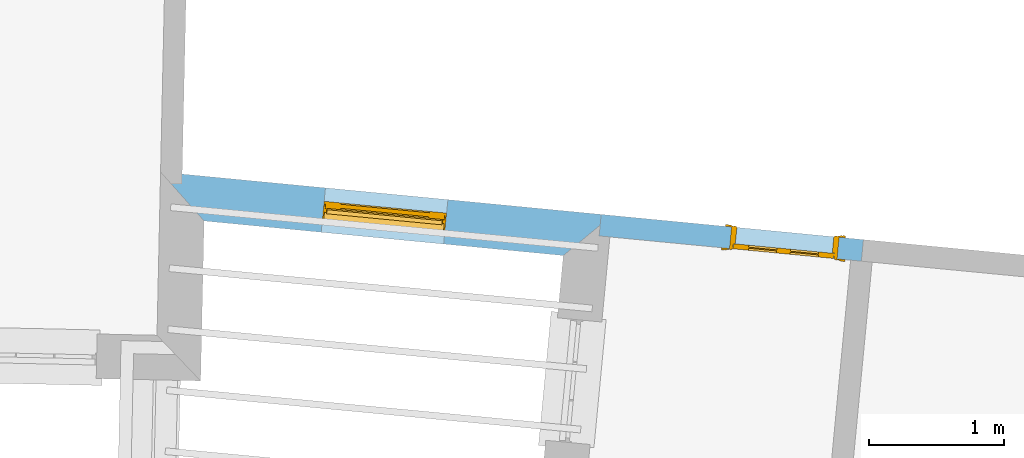
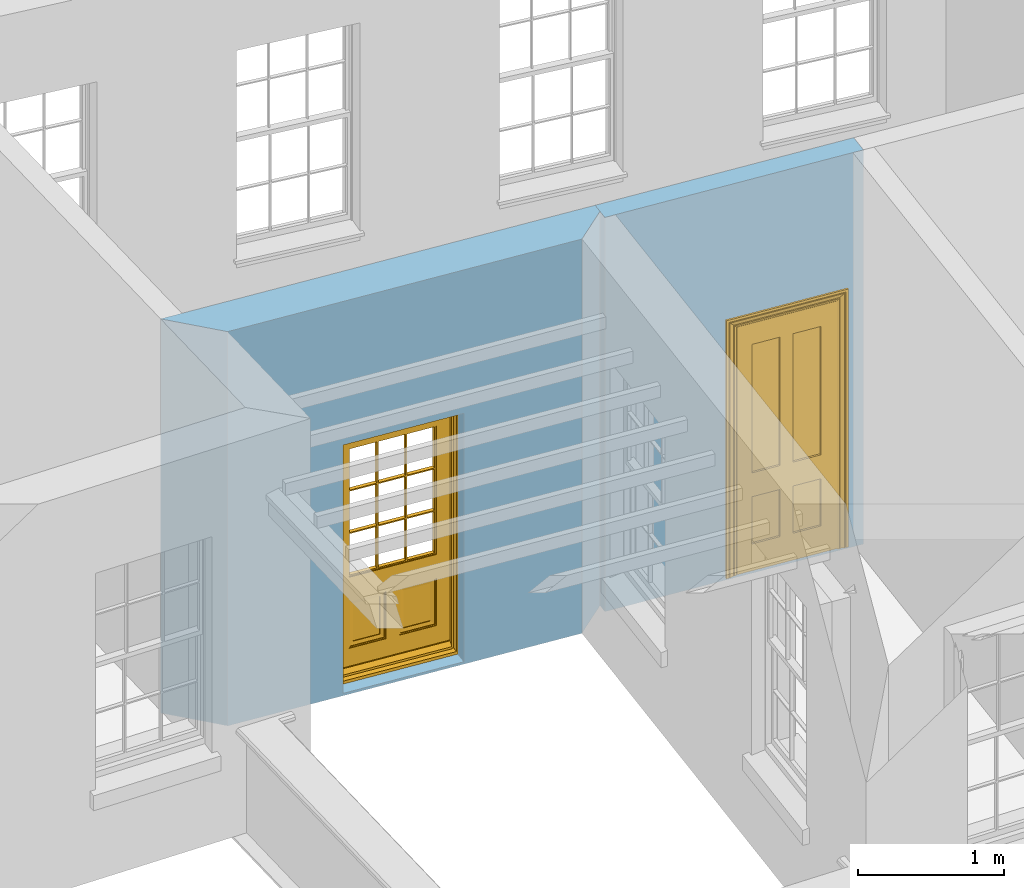
# One storey, part 6 of 12: 2 doors, 2 openings, plus 2 elements that do not belong to this part.
"""IFC2X3 building model written with IfcOpenShell, lengths in metres."""

from ifc_helpers import new_model, si_unit, frame, origin, place, context, subcontext, project, spatial, polyline, outline, extrude, faceted_brep, material, layer, layer_set, layer_usage, element, fill, save


model = new_model("IFC2X3")

# Units and contexts
model_context = context("Model", 3, world=origin())
body_context = subcontext(model_context, "Body", "Model", "MODEL_VIEW")
ifc_project = project(units=[si_unit("PLANEANGLEUNIT", "RADIAN"), si_unit("MASSUNIT", "GRAM", prefix="KILO"), si_unit("FORCEUNIT", "NEWTON", prefix="KILO"), si_unit("LENGTHUNIT", "METRE")], contexts=[model_context])

# Site, building, storey
site_placement = place(None, origin())
site = spatial("IfcSite", under=ifc_project, at=site_placement, CompositionType="ELEMENT")
building_placement = place(None, origin())
building = spatial("IfcBuilding", under=site, at=building_placement, Name="Building plot-18", CompositionType="ELEMENT")
storey_placement = place(None, frame((0.0, 0.0, 6.6)))
storey = spatial("IfcBuildingStorey", under=building, at=storey_placement, Name="Floor 1", CompositionType="ELEMENT", Elevation=6.6)

# Wall, opening, door
ifc_material_1 = material(Name="Masonry")
ifc_layer_1 = layer(ifc_material_1, 0.33, ventilated=False)
ifc_layer_set_1 = layer_set([ifc_layer_1], Name="My Wall")
ifc_layer_usage_1 = layer_usage(ifc_layer_set_1, "AXIS2", "NEGATIVE", 0.08)
wall_1_placement = place(storey_placement, origin())
wall_1 = element("IfcWallStandardCase", 1, at=wall_1_placement, inside=storey, material=ifc_layer_usage_1, Name="exterior", context=body_context, shape_type="SweptSolid", body=[
    extrude(outline(polyline([(93.8821736056846, 21.8550437590575), (94.2043231076959, 21.492511108805), (96.8612105097509, 21.2367803320634), (97.2209539104425, 21.533679413678), (93.8821736056846, 21.8550437590575)])), origin(), (0.0, 0.0, 1.0), 3.3),
])
opening_1_placement = place(storey_placement, frame((0.0, 0.0, 0.0199999999999996)))
opening_1 = element("IfcOpeningElement", 2, at=opening_1_placement, cuts=wall_1, Name="Opening", ObjectType="Opening", context=body_context, shape_type="SweptSolid", body=[
    extrude(outline(polyline([(95.0701477438461, 21.4091737394635), (95.9759614837646, 21.3219873381452), (96.0075785303965, 21.65046924383), (95.101764790478, 21.7376556451482), (95.0701477438461, 21.4091737394635)])), origin(), (0.0, 0.0, 1.0), 2.08),
])
door_1_placement = place(storey_placement, frame((95.0941000519006, 21.6580236680125, 0.0199999999999996), z_axis=(0.0, 0.0, 1.0), x_axis=(0.905813739918514, -0.0871864013182844, 0.0)))
door_1 = element("IfcDoor", 3, at=door_1_placement, inside=storey, Name="circulation outside door", OverallHeight=2.08, OverallWidth=0.91, context=body_context, shape_type="Brep", held_by="IfcProductRepresentation", body=[
    faceted_brep([(0.545, -0.055, 0.265), (0.745, -0.055, 0.265), (0.745, -0.05, 0.265), (0.545, -0.05, 0.265), (0.745, -0.05, 0.58), (0.545, -0.05, 0.58), (0.545, -0.055, 0.58), (0.515, -0.06, 0.235), (0.775, -0.06, 0.235), (0.745, -0.055, 0.58), (0.515, -0.06, 0.61), (0.515, -0.065, 0.235), (0.775, -0.065, 0.235), (0.775, -0.06, 0.61), (0.515, -0.065, 0.61), (0.785, -0.065, 0.225), (0.505, -0.065, 0.225), (0.775, -0.065, 0.61), (0.505, -0.065, 0.62), (0.785, -0.065, 0.62), (0.505, -0.07, 0.225), (0.785, -0.07, 0.225), (0.505, -0.07, 0.62), (0.785, -0.07, 0.62), (0.883, -0.07, 0.075), (0.898, -0.07, 0.075), (0.405, -0.07, 0.62), (0.405, -0.07, 0.225), (0.027, -0.07, 0.075), (0.785, -0.07, 0.82), (0.125, -0.07, 0.82), (0.405, -0.065, 0.62), (0.405, -0.065, 0.225), (0.898, -0.07, 2.068), (0.027, -0.08, 0.075), (0.883, -0.08, 0.075), (0.125, -0.07, 0.225), (0.012, -0.07, 0.075), (0.785, -0.06, 0.82), (0.125, -0.06, 0.82), (0.125, -0.07, 0.62), (0.125, -0.065, 0.62), (0.395, -0.065, 0.61), (0.395, -0.065, 0.235), (0.125, -0.065, 0.225), (0.785, -0.07, 1.895), (0.027, -0.11, 0.045), (0.883, -0.11, 0.045), (0.558333, -0.06, 0.83), (0.351667, -0.06, 0.83), (0.125, -0.07, 1.895), (0.125, -0.06, 1.895), (0.785, -0.06, 1.895), (0.012, -0.07, 2.068), (0.135, -0.065, 0.61), (0.395, -0.06, 0.61), (0.395, -0.06, 0.235), (0.135, -0.065, 0.235), (0.027, -0.11, 0.027), (0.883, -0.11, 0.027), (0.568333, -0.06, 0.83), (0.558333, -0.03, 0.83), (0.351667, -0.03, 0.83), (0.341667, -0.06, 0.83), (0.135, -0.06, 1.185), (0.135, -0.06, 1.53), (0.775, -0.06, 1.53), (0.775, -0.06, 1.185), (0.135, -0.06, 0.61), (0.365, -0.055, 0.58), (0.365, -0.055, 0.265), (0.135, -0.06, 0.235), (0.568333, -0.06, 1.175), (0.558333, -0.06, 1.175), (0.775, -0.06, 0.83), (0.558333, -0.03, 1.175), (0.785, -0.03, 0.82), (0.125, -0.03, 0.82), (0.351667, -0.03, 1.175), (0.351667, -0.06, 1.175), (0.341667, -0.06, 1.175), (0.135, -0.06, 0.83), (0.135, -0.06, 1.175), (0.135, -0.03, 1.185), (0.135, -0.03, 1.53), (0.135, -0.06, 1.54), (0.351667, -0.06, 1.885), (0.558333, -0.06, 1.885), (0.775, -0.03, 1.53), (0.775, -0.03, 1.185), (0.775, -0.06, 1.175), (0.775, -0.06, 1.54), (0.165, -0.055, 0.58), (0.365, -0.05, 0.58), (0.365, -0.05, 0.265), (0.165, -0.055, 0.265), (0.568333, -0.03, 0.83), (0.568333, -0.03, 1.175), (0.568333, -0.06, 1.185), (0.558333, -0.06, 1.185), (0.775, -0.03, 0.83), (0.785, -0.02, 0.82), (0.125, -0.02, 0.82), (0.341667, -0.03, 0.83), (0.341667, -0.03, 1.175), (0.351667, -0.06, 1.185), (0.341667, -0.06, 1.185), (0.135, -0.03, 0.83), (0.341667, -0.03, 1.185), (0.125, -0.03, 1.895), (0.341667, -0.03, 1.53), (0.341667, -0.06, 1.53), (0.135, -0.06, 1.885), (0.341667, -0.06, 1.54), (0.341667, -0.06, 1.885), (0.558333, -0.03, 1.885), (0.351667, -0.03, 1.885), (0.568333, -0.06, 1.885), (0.785, -0.03, 1.895), (0.568333, -0.03, 1.185), (0.568333, -0.06, 1.53), (0.568333, -0.03, 1.53), (0.568333, -0.06, 1.54), (0.775, -0.06, 1.885), (0.165, -0.05, 0.58), (0.165, -0.05, 0.265), (0.775, -0.03, 1.175), (0.558333, -0.06, 1.53), (0.351667, -0.03, 1.185), (0.558333, -0.03, 1.185), (0.505, -0.02, 0.62), (0.405, -0.02, 0.62), (0.125, -0.02, 1.895), (0.785, -0.02, 1.895), (0.351667, -0.06, 1.53), (0.135, -0.03, 1.175), (0.135, -0.03, 1.54), (0.341667, -0.03, 1.54), (0.135, -0.03, 1.885), (0.351667, -0.06, 1.54), (0.558333, -0.03, 1.54), (0.558333, -0.06, 1.54), (0.351667, -0.03, 1.54), (0.775, -0.03, 1.54), (0.568333, -0.03, 1.54), (0.775, -0.03, 1.885), (0.558333, -0.03, 1.53), (0.405, -0.02, 0.225), (0.505, -0.02, 0.225), (0.125, -0.02, 0.62), (0.785, -0.02, 0.62), (0.012, -0.02, 2.068), (0.898, -0.02, 2.068), (0.351667, -0.03, 1.53), (0.341667, -0.03, 1.885), (0.568333, -0.03, 1.885), (0.405, -0.025, 0.225), (0.405, -0.025, 0.62), (0.505, -0.025, 0.62), (0.505, -0.025, 0.225), (0.898, -0.02, 0.027), (0.012, -0.02, 0.027), (0.125, -0.025, 0.62), (0.785, -0.025, 0.62), (0.395, -0.025, 0.235), (0.395, -0.025, 0.61), (0.125, -0.02, 0.225), (0.125, -0.025, 0.225), (0.515, -0.025, 0.61), (0.515, -0.025, 0.235), (0.785, -0.02, 0.225), (0.785, -0.025, 0.225), (0.135, -0.025, 0.61), (0.775, -0.025, 0.61), (0.135, -0.025, 0.235), (0.395, -0.03, 0.235), (0.395, -0.03, 0.61), (0.515, -0.03, 0.61), (0.515, -0.03, 0.235), (0.775, -0.025, 0.235), (0.135, -0.03, 0.61), (0.775, -0.03, 0.61), (0.135, -0.03, 0.235), (0.365, -0.035, 0.265), (0.365, -0.035, 0.58), (0.545, -0.035, 0.58), (0.545, -0.035, 0.265), (0.775, -0.03, 0.235), (0.165, -0.035, 0.58), (0.745, -0.035, 0.58), (0.165, -0.035, 0.265), (0.365, -0.04, 0.58), (0.365, -0.04, 0.265), (0.545, -0.04, 0.58), (0.545, -0.04, 0.265), (0.745, -0.035, 0.265), (0.165, -0.04, 0.58), (0.745, -0.04, 0.58), (0.165, -0.04, 0.265), (0.745, -0.04, 0.265), (0.885, -0.072, 0.025), (0.025, -0.072, 0.025), (0.025, -0.1, 0.025), (0.885, -0.1, 0.025), (0.9, -0.02, 0.025), (0.01, -0.02, 0.025), (0.9, -0.072, 0.025), (0.91, -0.02, 0.0), (0.0, -0.02, 0.0), (0.01, -0.072, 0.025), (0.9, -0.072, 2.07), (0.9, -0.02, 2.07), (0.885, -0.072, 2.055), (0.91, -0.02, 2.08), (0.01, -0.02, 2.07), (0.0, -0.02, 2.08), (0.01, -0.072, 2.07), (0.025, -0.072, 2.055), (0.0, -0.15, 2.08), (0.91, -0.15, 2.08), (0.01, -0.15, 2.07), (0.9, -0.15, 2.07), (0.01, -0.1, 2.07), (0.9, -0.1, 2.07), (0.0, -0.15, 0.0), (0.91, -0.15, 0.0), (0.01, -0.15, 0.025), (0.9, -0.15, 0.025), (0.01, -0.1, 0.025), (0.025, -0.1, 2.055), (0.9, -0.1, 0.025), (0.885, -0.1, 2.055), (0.898, -0.07, 0.027), (0.012, -0.07, 0.027), (0.883, -0.07, 0.027), (0.027, -0.07, 0.027)], [[[0, 1, 2, 3]], [[2, 4, 5, 3]], [[0, 3, 5, 6]], [[1, 0, 7, 8]], [[9, 4, 2, 1]], [[9, 6, 5, 4]], [[0, 6, 10, 7]], [[8, 7, 11, 12]], [[8, 13, 9, 1]], [[13, 10, 6, 9]], [[7, 10, 14, 11]], [[15, 12, 11, 16]], [[12, 17, 13, 8]], [[17, 14, 10, 13]], [[18, 16, 11, 14]], [[15, 19, 17, 12]], [[15, 16, 20, 21]], [[14, 17, 19, 18]], [[16, 18, 22, 20]], [[21, 23, 19, 15]], [[24, 25, 21, 20]], [[23, 22, 18, 19]], [[20, 22, 26, 27]], [[23, 21, 25]], [[28, 24, 20, 27]], [[22, 23, 29]], [[29, 30, 26, 22]], [[27, 26, 31, 32]], [[23, 25, 33, 29]], [[34, 35, 24, 28]], [[28, 27, 36, 37]], [[38, 39, 30, 29]], [[26, 30, 40]], [[26, 40, 41, 31]], [[42, 43, 32, 31]], [[32, 44, 36, 27]], [[33, 45, 29]], [[46, 47, 35, 34]], [[36, 40, 37]], [[39, 38, 48, 49]], [[50, 30, 39, 51]], [[29, 45, 52, 38]], [[53, 37, 40, 30]], [[44, 41, 40, 36]], [[31, 41, 54, 42]], [[43, 42, 55, 56]], [[57, 44, 32, 43]], [[50, 45, 33, 53]], [[47, 46, 58, 59]], [[60, 48, 38]], [[49, 48, 61, 62]], [[49, 63, 39]], [[50, 53, 30]], [[51, 39, 64, 65]], [[45, 50, 51, 52]], [[66, 67, 38, 52]], [[57, 54, 41, 44]], [[42, 54, 68, 55]], [[56, 55, 69, 70]], [[56, 71, 57, 43]], [[60, 72, 73, 48]], [[60, 38, 74]], [[48, 73, 75, 61]], [[76, 77, 62, 61]], [[62, 78, 79, 49]], [[49, 79, 80, 63]], [[63, 81, 39]], [[82, 64, 39]], [[65, 64, 83, 84]], [[85, 51, 65]], [[52, 51, 86, 87]], [[88, 89, 67, 66]], [[90, 38, 67]], [[91, 66, 52]], [[71, 68, 54, 57]], [[55, 68, 92, 69]], [[69, 93, 94, 70]], [[70, 95, 71, 56]], [[96, 97, 72, 60]], [[73, 72, 98, 99]], [[74, 38, 90]], [[100, 96, 60, 74]], [[75, 73, 79, 78]], [[61, 75, 97, 96]], [[101, 102, 77, 76]], [[77, 103, 62]], [[96, 76, 61]], [[103, 104, 78, 62]], [[80, 79, 105, 106]], [[63, 80, 104, 103]], [[81, 63, 103, 107]], [[81, 82, 39]], [[106, 64, 82, 80]], [[106, 108, 83, 64]], [[84, 83, 77, 109]], [[110, 111, 65, 84]], [[112, 51, 85]], [[113, 85, 65, 111]], [[114, 86, 51]], [[115, 87, 86, 116]], [[117, 52, 87]], [[118, 76, 89, 88]], [[119, 98, 67, 89]], [[120, 121, 88, 66]], [[67, 98, 72, 90]], [[91, 122, 120, 66]], [[91, 52, 123]], [[95, 92, 68, 71]], [[69, 92, 124, 93]], [[94, 93, 124, 125]], [[94, 125, 95, 70]], [[72, 97, 126, 90]], [[127, 99, 98, 120]], [[99, 105, 79, 73]], [[74, 90, 126, 100]], [[96, 100, 76]], [[128, 129, 75, 78]], [[97, 75, 129, 119]], [[130, 131, 102, 101]], [[109, 77, 102, 132]], [[133, 101, 76, 118]], [[77, 107, 103]], [[78, 104, 108, 128]], [[111, 106, 105, 134]], [[104, 80, 82, 135]], [[107, 135, 82, 81]], [[110, 108, 106, 111]], [[104, 135, 83, 108]], [[83, 135, 77]], [[136, 84, 109]], [[110, 84, 136, 137]], [[114, 51, 112]], [[85, 136, 138, 112]], [[113, 137, 136, 85]], [[111, 134, 139, 113]], [[86, 114, 113, 139]], [[140, 141, 87, 115]], [[139, 142, 116, 86]], [[109, 118, 115, 116]], [[117, 123, 52]], [[117, 87, 141, 122]], [[126, 89, 76]], [[143, 118, 88]], [[120, 98, 119, 121]], [[119, 89, 126, 97]], [[144, 143, 88, 121]], [[144, 122, 91, 143]], [[127, 120, 122, 141]], [[143, 91, 123, 145]], [[124, 92, 95, 125]], [[146, 129, 99, 127]], [[99, 129, 128, 105]], [[100, 126, 76]], [[121, 119, 129, 146]], [[147, 131, 130, 148]], [[131, 149, 102]], [[130, 101, 150]], [[102, 151, 132]], [[118, 109, 132, 133]], [[101, 133, 152]], [[107, 77, 135]], [[153, 128, 108, 110]], [[134, 105, 128, 153]], [[109, 138, 136]], [[153, 110, 137, 142]], [[154, 114, 112, 138]], [[137, 113, 114, 154]], [[141, 139, 134, 127]], [[141, 140, 142, 139]], [[144, 140, 115, 155]], [[142, 137, 154, 116]], [[155, 115, 118]], [[116, 154, 109]], [[117, 155, 145, 123]], [[122, 144, 155, 117]], [[143, 145, 118]], [[121, 146, 140, 144]], [[146, 127, 134, 153]], [[156, 157, 131, 147]], [[148, 130, 158, 159]], [[148, 160, 161, 147]], [[157, 162, 149, 131]], [[161, 151, 102, 149]], [[101, 152, 160, 150]], [[163, 158, 130, 150]], [[151, 152, 133, 132]], [[154, 138, 109]], [[142, 140, 146, 153]], [[145, 155, 118]], [[157, 156, 164, 165]], [[147, 166, 167, 156]], [[168, 169, 159, 158]], [[170, 148, 159, 171]], [[148, 170, 160]], [[166, 147, 161]], [[172, 162, 157, 165]], [[166, 149, 162, 167]], [[166, 161, 149]], [[150, 160, 170]], [[163, 173, 168, 158]], [[171, 163, 150, 170]], [[174, 164, 156, 167]], [[175, 176, 165, 164]], [[169, 168, 177, 178]], [[171, 159, 169, 179]], [[167, 162, 172, 174]], [[176, 180, 172, 165]], [[179, 173, 163, 171]], [[181, 177, 168, 173]], [[164, 174, 182, 175]], [[183, 184, 176, 175]], [[178, 177, 185, 186]], [[179, 169, 178, 187]], [[174, 172, 180, 182]], [[184, 188, 180, 176]], [[187, 181, 173, 179]], [[189, 185, 177, 181]], [[175, 182, 190, 183]], [[191, 184, 183, 192]], [[185, 193, 194, 186]], [[187, 178, 186, 195]], [[182, 180, 188, 190]], [[191, 196, 188, 184]], [[195, 189, 181, 187]], [[197, 193, 185, 189]], [[183, 190, 198, 192]], [[198, 196, 191, 192]], [[194, 193, 197, 199]], [[195, 186, 194, 199]], [[188, 196, 198, 190]], [[197, 189, 195, 199]], [[200, 201, 202, 203]], [[201, 200, 204, 205]], [[206, 204, 200]], [[204, 207, 208, 205]], [[209, 201, 205]], [[210, 211, 204, 206]], [[206, 200, 212, 210]], [[211, 213, 207, 204]], [[214, 205, 208, 215]], [[216, 217, 201, 209]], [[205, 214, 216, 209]], [[216, 214, 211, 210]], [[210, 212, 217, 216]], [[214, 215, 213, 211]], [[218, 219, 213, 215]], [[219, 218, 220, 221]], [[221, 220, 222, 223]], [[215, 208, 224, 218]], [[225, 224, 208, 207]], [[224, 226, 220, 218]], [[224, 225, 227, 226]], [[219, 225, 207, 213]], [[228, 222, 220, 226]], [[219, 221, 227, 225]], [[226, 227, 203, 202]], [[202, 229, 222, 228]], [[228, 226, 202]], [[227, 221, 223, 230]], [[230, 203, 227]], [[217, 229, 202, 201]], [[231, 223, 222, 229]], [[230, 223, 231, 203]], [[231, 229, 217, 212]], [[212, 200, 203, 231]], [[33, 152, 151, 53]], [[25, 160, 152, 33]], [[161, 37, 53, 151]], [[232, 160, 25]], [[161, 233, 37]], [[160, 232, 234]], [[24, 234, 232, 25]], [[233, 161, 235]], [[37, 233, 235, 28]], [[161, 160, 234, 235]], [[35, 47, 234, 24]], [[28, 235, 46, 34]], [[58, 235, 234, 59]], [[59, 234, 47]], [[58, 46, 235]]]),
])
fill(opening_1, door_1)

ifc_material_2 = material(Name="Masonry")
ifc_layer_2 = layer(ifc_material_2, 0.16, ventilated=False)
ifc_layer_set_2 = layer_set([ifc_layer_2], Name="My Wall")
ifc_layer_usage_2 = layer_usage(ifc_layer_set_2, "AXIS2", "NEGATIVE", 0.08)
wall_2_placement = place(storey_placement, origin())
wall_2 = element("IfcWallStandardCase", 4, at=wall_2_placement, inside=storey, material=ifc_layer_usage_2, Name="interior", context=body_context, shape_type="SweptSolid", body=[
    extrude(outline(polyline([(99.0657825946003, 21.1953714806939), (99.0811120717551, 21.3546354349653), (97.1414081276401, 21.5413358558768), (97.1260786504853, 21.3820719016054), (99.0657825946003, 21.1953714806939)])), origin(), (0.0, 0.0, 1.0), 3.3),
])
opening_2_placement = place(storey_placement, frame((0.0, 0.0, 0.0199999999999996)))
opening_2 = element("IfcOpeningElement", 5, at=opening_2_placement, cuts=wall_2, Name="Opening", ObjectType="Opening", context=body_context, shape_type="SweptSolid", body=[
    extrude(outline(polyline([(98.9019401231998, 21.3718810967645), (98.1056203518429, 21.4485284825388), (98.090290874688, 21.2892645282674), (98.886610646045, 21.2126171424931), (98.9019401231998, 21.3718810967645)])), origin(), (0.0, 0.0, 1.0), 2.1),
])
door_2_placement = place(storey_placement, frame((98.8942753846224, 21.2922491196288, 0.0199999999999996), z_axis=(0.0, 0.0, 1.0), x_axis=(-0.796319771356949, 0.0766473857742866, 0.0)))
door_2 = element("IfcDoor", 6, at=door_2_placement, inside=storey, Name="toilet inside door", OverallHeight=2.1, OverallWidth=0.8, context=body_context, shape_type="Brep", held_by="IfcProductRepresentation", body=[
    faceted_brep([(0.773, 0.08, 1.895), (0.66, 0.08, 1.895), (0.66, 0.08, 2.073), (0.773, 0.08, 2.073), (0.773, 0.08, 0.82), (0.66, 0.08, 0.82), (0.45, 0.08, 1.895), (0.45, 0.08, 2.073), (0.773, 0.08, 0.62), (0.66, 0.08, 0.62), (0.66, 0.065, 0.82), (0.66, 0.065, 1.895), (0.45, 0.065, 1.895), (0.35, 0.08, 1.895), (0.35, 0.08, 2.073), (0.773, 0.08, 0.225), (0.66, 0.08, 0.225), (0.45, 0.08, 0.62), (0.45, 0.08, 0.82), (0.45, 0.065, 0.82), (0.35, 0.08, 0.82), (0.14, 0.08, 2.073), (0.14, 0.08, 1.895), (0.773, 0.08, 0.0), (0.66, 0.08, 0.0), (0.66, 0.065, 0.225), (0.66, 0.065, 0.62), (0.45, 0.065, 0.62), (0.35, 0.08, 0.62), (0.35, 0.065, 0.82), (0.35, 0.065, 1.895), (0.14, 0.065, 1.895), (0.027, 0.08, 2.073), (0.027, 0.08, 1.895), (0.773, 0.042, 0.0), (0.66, 0.042, 0.0), (0.45, 0.08, 0.0), (0.45, 0.08, 0.225), (0.45, 0.065, 0.225), (0.35, 0.08, 0.225), (0.14, 0.08, 0.82), (0.14, 0.08, 0.62), (0.14, 0.065, 0.82), (0.027, 0.08, 0.82), (0.773, 0.042, 0.225), (0.66, 0.042, 0.225), (0.45, 0.042, 0.0), (0.35, 0.08, 0.0), (0.35, 0.065, 0.225), (0.35, 0.065, 0.62), (0.14, 0.065, 0.62), (0.027, 0.08, 0.62), (0.773, 0.042, 0.62), (0.66, 0.042, 0.62), (0.45, 0.042, 0.225), (0.35, 0.042, 0.0), (0.14, 0.08, 0.225), (0.14, 0.08, 0.0), (0.14, 0.065, 0.225), (0.027, 0.08, 0.225), (0.773, 0.042, 0.82), (0.66, 0.042, 0.82), (0.66, 0.057, 0.62), (0.66, 0.057, 0.225), (0.45, 0.057, 0.225), (0.35, 0.042, 0.225), (0.14, 0.042, 0.0), (0.027, 0.08, 0.0), (0.773, 0.042, 1.895), (0.66, 0.042, 1.895), (0.45, 0.042, 0.62), (0.45, 0.042, 0.82), (0.45, 0.057, 0.62), (0.35, 0.042, 0.62), (0.14, 0.042, 0.225), (0.027, 0.042, 0.0), (0.773, 0.042, 2.073), (0.66, 0.042, 2.073), (0.66, 0.057, 1.895), (0.66, 0.057, 0.82), (0.45, 0.057, 0.82), (0.35, 0.042, 0.82), (0.35, 0.057, 0.62), (0.35, 0.057, 0.225), (0.14, 0.057, 0.225), (0.027, 0.042, 0.225), (0.45, 0.042, 1.895), (0.45, 0.042, 2.073), (0.45, 0.057, 1.895), (0.35, 0.042, 1.895), (0.14, 0.042, 0.82), (0.14, 0.042, 0.62), (0.14, 0.057, 0.62), (0.027, 0.042, 0.62), (0.35, 0.042, 2.073), (0.35, 0.057, 1.895), (0.35, 0.057, 0.82), (0.14, 0.057, 0.82), (0.027, 0.042, 0.82), (0.14, 0.042, 2.073), (0.14, 0.042, 1.895), (0.14, 0.057, 1.895), (0.027, 0.042, 1.895), (0.027, 0.042, 2.073), (0.02, 0.085, 0.0), (0.005, 0.09, 0.0), (0.005, 0.09, 2.095), (0.02, 0.085, 2.08), (0.02, 0.08, 0.0), (0.0, 0.085, 0.0), (0.0, 0.085, 2.1), (0.795, 0.09, 2.095), (0.78, 0.085, 2.08), (0.02, 0.08, 2.08), (0.0, 0.08, 0.0), (-0.032, 0.095, 0.0), (-0.032, 0.095, 2.132), (0.8, 0.085, 2.1), (0.795, 0.09, 0.0), (0.78, 0.085, 0.0), (0.78, 0.08, 2.08), (0.04, 0.04, 0.0), (0.025, 0.04, 0.0), (0.025, 0.04, 2.075), (0.04, 0.04, 2.06), (-0.04, 0.09, 0.0), (-0.04, 0.09, 2.14), (0.832, 0.095, 2.132), (0.8, 0.085, 0.0), (0.78, 0.08, 0.0), (0.8, 0.08, 0.0), (0.86, 0.08, 0.0), (0.86, 0.08, 2.16), (0.8, 0.08, 2.1), (-0.06, 0.08, 2.16), (0.0, 0.08, 2.1), (-0.06, 0.08, 0.0), (-0.04, 0.095, 0.0), (-0.04, 0.095, 2.14), (0.84, 0.09, 2.14), (0.832, 0.095, 0.0), (0.84, 0.09, 0.0), (0.86, 0.095, 0.0), (0.86, 0.095, 2.16), (-0.06, 0.095, 2.16), (-0.06, 0.095, 0.0), (0.84, 0.095, 0.0), (0.84, 0.095, 2.14), (-0.025, -0.095, 0.0), (-0.025, -0.09, 0.0), (-0.025, -0.09, 2.125), (-0.025, -0.095, 2.125), (-0.017, -0.095, 0.0), (-0.017, -0.095, 2.117), (0.825, -0.09, 2.125), (0.825, -0.095, 2.125), (0.825, -0.095, 0.0), (0.845, -0.095, 0.0), (-0.045, -0.095, 2.145), (-0.045, -0.095, 0.0), (0.845, -0.095, 2.145), (0.015, -0.085, 0.0), (0.015, -0.085, 2.085), (0.817, -0.095, 2.117), (0.825, -0.09, 0.0), (0.845, -0.08, 0.0), (0.845, -0.08, 2.145), (-0.045, -0.08, 2.145), (-0.045, -0.08, 0.0), (0.02, -0.09, 0.0), (0.02, -0.09, 2.08), (0.785, -0.085, 2.085), (0.817, -0.095, 0.0), (0.8, -0.08, 0.0), (0.8, -0.08, 2.1), (0.0, -0.08, 2.1), (0.0, -0.08, 0.0), (0.035, -0.085, 0.0), (0.035, -0.085, 2.065), (0.78, -0.09, 2.08), (0.785, -0.085, 0.0), (0.775, 0.04, 2.075), (0.76, 0.04, 2.06), (0.035, -0.08, 2.065), (0.035, -0.08, 0.0), (0.765, -0.085, 2.065), (0.78, -0.09, 0.0), (0.765, -0.08, 0.0), (0.765, -0.08, 2.065), (0.765, -0.085, 0.0), (0.04, -0.08, 2.06), (0.04, -0.08, 0.0), (0.76, -0.08, 2.06), (0.76, -0.08, 0.0), (0.76, 0.04, 0.0), (0.775, 0.04, 0.0), (0.025, 0.08, 0.0), (0.025, 0.08, 2.075), (0.775, 0.08, 0.0), (0.775, 0.08, 2.075)], [[[0, 1, 2, 3]], [[1, 0, 4, 5]], [[1, 6, 7, 2]], [[8, 9, 5, 4]], [[1, 5, 10, 11]], [[6, 1, 11, 12]], [[6, 13, 14, 7]], [[15, 16, 9, 8]], [[9, 17, 18, 5]], [[5, 18, 19, 10]], [[10, 19, 12, 11]], [[18, 6, 12, 19]], [[18, 20, 13, 6]], [[21, 14, 13, 22]], [[23, 24, 16, 15]], [[9, 16, 25, 26]], [[17, 9, 26, 27]], [[17, 28, 20, 18]], [[13, 20, 29, 30]], [[22, 13, 30, 31]], [[32, 21, 22, 33]], [[34, 35, 24, 23]], [[24, 36, 37, 16]], [[16, 37, 38, 25]], [[25, 38, 27, 26]], [[37, 17, 27, 38]], [[37, 39, 28, 17]], [[40, 20, 28, 41]], [[20, 40, 42, 29]], [[31, 30, 29, 42]], [[40, 22, 31, 42]], [[33, 22, 40, 43]], [[35, 34, 44, 45]], [[35, 46, 36, 24]], [[36, 47, 39, 37]], [[28, 39, 48, 49]], [[41, 28, 49, 50]], [[43, 40, 41, 51]], [[45, 44, 52, 53]], [[46, 35, 45, 54]], [[46, 55, 47, 36]], [[56, 39, 47, 57]], [[39, 56, 58, 48]], [[50, 49, 48, 58]], [[56, 41, 50, 58]], [[51, 41, 56, 59]], [[53, 52, 60, 61]], [[45, 53, 62, 63]], [[54, 45, 63, 64]], [[55, 46, 54, 65]], [[55, 66, 57, 47]], [[59, 56, 57, 67]], [[61, 60, 68, 69]], [[70, 53, 61, 71]], [[53, 70, 72, 62]], [[72, 64, 63, 62]], [[70, 54, 64, 72]], [[65, 54, 70, 73]], [[65, 74, 66, 55]], [[67, 57, 66, 75]], [[69, 68, 76, 77]], [[61, 69, 78, 79]], [[71, 61, 79, 80]], [[73, 70, 71, 81]], [[65, 73, 82, 83]], [[74, 65, 83, 84]], [[74, 85, 75, 66]], [[86, 69, 77, 87]], [[69, 86, 88, 78]], [[88, 80, 79, 78]], [[86, 71, 80, 88]], [[81, 71, 86, 89]], [[73, 81, 90, 91]], [[73, 91, 92, 82]], [[83, 82, 92, 84]], [[91, 74, 84, 92]], [[91, 93, 85, 74]], [[89, 86, 87, 94]], [[81, 89, 95, 96]], [[90, 81, 96, 97]], [[90, 98, 93, 91]], [[94, 99, 100, 89]], [[89, 100, 101, 95]], [[101, 97, 96, 95]], [[100, 90, 97, 101]], [[100, 102, 98, 90]], [[99, 103, 102, 100]], [[32, 103, 99, 21]], [[102, 103, 32, 33]], [[98, 102, 33, 43]], [[21, 99, 94, 14]], [[94, 87, 7, 14]], [[7, 87, 77, 2]], [[76, 3, 2, 77]], [[43, 51, 93, 98]], [[51, 59, 85, 93]], [[67, 75, 85, 59]], [[34, 23, 15, 44]], [[44, 15, 8, 52]], [[52, 8, 4, 60]], [[0, 68, 60, 4]], [[0, 3, 76, 68]], [[104, 105, 106, 107]], [[104, 108, 109, 105]], [[105, 109, 110, 106]], [[107, 106, 111, 112]], [[107, 113, 108, 104]], [[114, 109, 108]], [[109, 115, 116, 110]], [[106, 110, 117, 111]], [[112, 111, 118, 119]], [[113, 107, 112, 120]], [[121, 122, 123, 124]], [[115, 109, 114, 125]], [[115, 125, 126, 116]], [[110, 116, 127, 117]], [[111, 117, 128, 118]], [[118, 128, 129, 119]], [[120, 112, 119, 129]], [[130, 129, 128]], [[130, 131, 132, 133]], [[133, 132, 134, 135]], [[135, 134, 136, 114]], [[136, 125, 114]], [[125, 137, 138, 126]], [[116, 126, 139, 127]], [[117, 127, 140, 128]], [[141, 130, 128, 140]], [[131, 130, 141]], [[131, 142, 143, 132]], [[132, 143, 144, 134]], [[134, 144, 145, 136]], [[137, 125, 136, 145]], [[143, 142, 146]], [[143, 146, 147]], [[137, 145, 144]], [[143, 147, 138]], [[138, 137, 144]], [[143, 138, 144]], [[126, 138, 147, 139]], [[127, 139, 141, 140]], [[142, 131, 141, 146]], [[139, 147, 146, 141]], [[148, 149, 150, 151]], [[149, 152, 153, 150]], [[151, 150, 154, 155]], [[155, 156, 157]], [[158, 159, 148]], [[158, 148, 151]], [[155, 157, 160]], [[158, 151, 155]], [[155, 160, 158]], [[152, 161, 162, 153]], [[150, 153, 163, 154]], [[155, 154, 164, 156]], [[156, 164, 165, 157]], [[157, 165, 166, 160]], [[160, 166, 167, 158]], [[158, 167, 168, 159]], [[161, 169, 170, 162]], [[153, 162, 171, 163]], [[154, 163, 172, 164]], [[165, 164, 173]], [[165, 173, 174, 166]], [[166, 174, 175, 167]], [[167, 175, 176, 168]], [[169, 177, 178, 170]], [[162, 170, 179, 171]], [[163, 171, 180, 172]], [[172, 180, 173, 164]], [[124, 123, 181, 182]], [[183, 178, 177, 184]], [[170, 178, 185, 179]], [[171, 179, 186, 180]], [[187, 173, 180]], [[185, 188, 187, 189]], [[188, 185, 178, 183]], [[179, 185, 189, 186]], [[189, 187, 180, 186]], [[190, 183, 184, 191]], [[192, 188, 183, 190]], [[191, 184, 122, 121]], [[124, 190, 191, 121]], [[193, 187, 188, 192]], [[182, 192, 190, 124]], [[184, 176, 122]], [[194, 195, 187, 193]], [[192, 182, 194, 193]], [[161, 176, 184]], [[114, 108, 122, 176]], [[173, 187, 195]], [[152, 149, 176, 161]], [[169, 161, 184, 177]], [[196, 122, 108]], [[176, 175, 135, 114]], [[173, 195, 129, 130]], [[176, 149, 168]], [[123, 122, 196, 197]], [[196, 108, 113, 197]], [[175, 174, 133, 135]], [[198, 129, 195]], [[133, 174, 173, 130]], [[159, 168, 149, 148]], [[181, 123, 197, 199]], [[197, 113, 120, 199]], [[199, 120, 129, 198]], [[195, 181, 199, 198]], [[195, 194, 182, 181]]]),
])
fill(opening_2, door_2)

save(model, "model.ifc")
